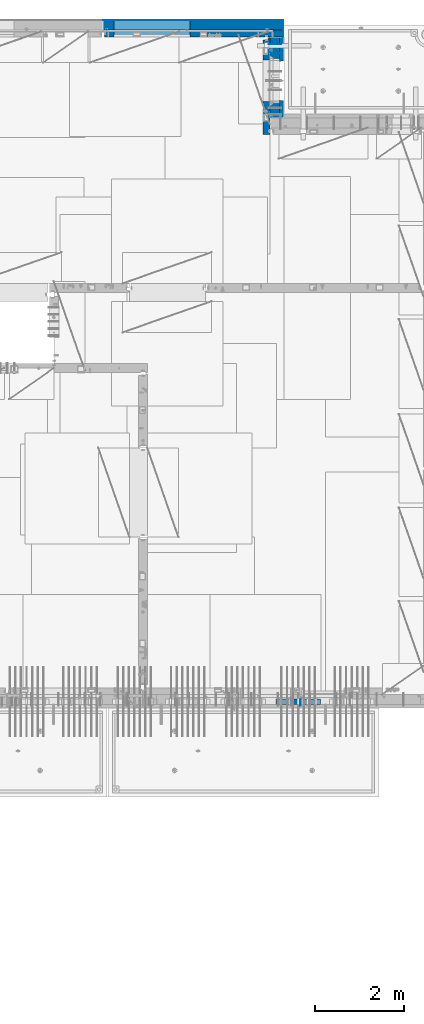
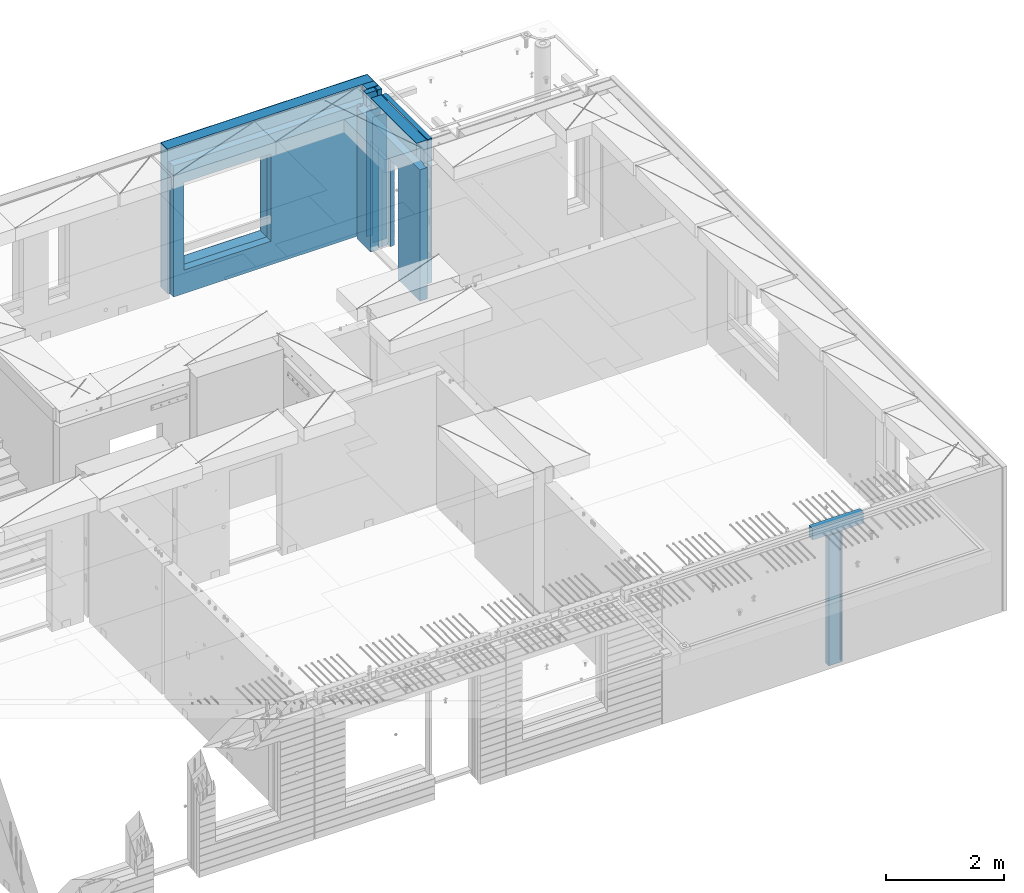
# One storey, part 232 of 341: 13 walls, 5 elements without a shape of their own.
"""IFC2X3 building model written with IfcOpenShell, lengths in millimetres."""

from ifc_helpers import new_model, si_unit, frame, origin_with_axes, place, context, subcontext, project, spatial, faceted_brep, material, type_object, element, aggregate, save


model = new_model("IFC2X3")

# Units and contexts
model_context = context("Model", 3, precision=1e-05, world=origin_with_axes())
body_context = subcontext(model_context, "Body", "Model", "MODEL_VIEW")
ifc_project = project(units=[si_unit("LENGTHUNIT", "METRE", prefix="MILLI"), si_unit("AREAUNIT", "SQUARE_METRE"), si_unit("VOLUMEUNIT", "CUBIC_METRE"), si_unit("MASSUNIT", "GRAM", prefix="KILO"), si_unit("TIMEUNIT", "SECOND"), si_unit("PLANEANGLEUNIT", "RADIAN"), si_unit("SOLIDANGLEUNIT", "STERADIAN"), si_unit("THERMODYNAMICTEMPERATUREUNIT", "DEGREE_CELSIUS"), si_unit("LUMINOUSINTENSITYUNIT", "LUMEN")], contexts=[model_context])

# Site, building, storey
site_placement = place(None, origin_with_axes())
site = spatial("IfcSite", under=ifc_project, at=site_placement, CompositionType="ELEMENT")
building_placement = place(site_placement, origin_with_axes())
building = spatial("IfcBuilding", under=site, at=building_placement, CompositionType="ELEMENT")
storey_placement = place(building_placement, origin_with_axes())
storey = spatial("IfcBuildingStorey", under=building, at=storey_placement, Name="5", CompositionType="ELEMENT", Elevation=0.0)

# Assembly, wall
assembly_1_placement = place(storey_placement, origin_with_axes())
assembly_1 = element("IfcElementAssembly", 1, at=assembly_1_placement, inside=storey, AssemblyPlace="NOTDEFINED", PredefinedType="REINFORCEMENT_UNIT")
ifc_material_1 = material(Name="Undefined")
wall_type_1 = type_object("IfcWallType", PredefinedType="NOTDEFINED")
wall_1_placement = place(assembly_1_placement, frame((32144.9998946285, 7780.0, 95115.0), z_axis=(0.0, 0.0, 1.0), x_axis=(0.0, -1.0, 0.0)))
wall_1 = element("IfcWall", 2, at=wall_1_placement, type_object=wall_type_1, material=ifc_material_1, Name="(PD)", context=body_context, shape_type="Brep", body=[
    faceted_brep([(0.0, 5.0, -1300.0), (0.0, 5.0, 1300.0), (180.0, 5.0, 1300.0), (180.0, 5.0, -1300.0), (0.0, -5.0, 1300.0), (180.0, -5.0, 1300.0), (0.0, -5.0, -1300.0), (180.0, -5.0, -1300.0)], [[[0, 1, 2, 3]], [[1, 4, 5, 2]], [[4, 6, 7, 5]], [[6, 0, 3, 7]], [[5, 7, 3, 2]], [[6, 4, 1, 0]]]),
])

# Assembly, walls
assembly_2_placement = place(storey_placement, origin_with_axes())
assembly_2 = element("IfcElementAssembly", 3, at=assembly_2_placement, inside=storey, AssemblyPlace="NOTDEFINED", PredefinedType="REINFORCEMENT_UNIT")
wall_2_placement = place(assembly_2_placement, frame((31429.9951872276, 22245.0, 95115.0), z_axis=(0.0, 0.0, 1.0), x_axis=(1.0, 0.0, 0.0)))
wall_2 = element("IfcWall", 4, at=wall_2_placement, type_object=wall_type_1, material=ifc_material_1, Name="(PD)", context=body_context, shape_type="Brep", body=[
    faceted_brep([(0.0, 5.0, -1300.0), (0.0, 5.0, 1300.0), (280.0, 5.0, 1300.0), (280.0, 5.0, -1300.0), (0.0, -5.0, 1300.0), (280.0, -5.0, 1300.0), (0.0, -5.0, -1300.0), (280.0, -5.0, -1300.0)], [[[0, 1, 2, 3]], [[1, 4, 5, 2]], [[4, 6, 7, 5]], [[6, 0, 3, 7]], [[5, 7, 3, 2]], [[6, 4, 1, 0]]]),
])
wall_3_placement = place(assembly_2_placement, frame((31429.9951872276, 22454.9997558594, 95115.0), z_axis=(0.0, 0.0, 1.0), x_axis=(1.0, 0.0, 0.0)))
wall_3 = element("IfcWall", 5, at=wall_3_placement, type_object=wall_type_1, material=ifc_material_1, Name="(PD)", context=body_context, shape_type="Brep", body=[
    faceted_brep([(0.0, 5.0, -1300.0), (0.0, 5.0, 1300.0), (280.0, 5.0, 1300.0), (280.0, 5.0, -1300.0), (0.0, -5.0, 1300.0), (280.0, -5.0, 1300.0), (0.0, -5.0, -1300.0), (280.0, -5.0, -1300.0)], [[[0, 1, 2, 3]], [[1, 4, 5, 2]], [[4, 6, 7, 5]], [[6, 0, 3, 7]], [[5, 7, 3, 2]], [[6, 4, 1, 0]]]),
])

# Assemblies, wall
assembly_3_placement = place(storey_placement, origin_with_axes())
assembly_3 = element("IfcElementAssembly", 6, at=assembly_3_placement, inside=storey, AssemblyPlace="NOTDEFINED", PredefinedType="REINFORCEMENT_UNIT")
assembly_4_placement = place(assembly_3_placement, origin_with_axes())
assembly_4 = element("IfcElementAssembly", 7, at=assembly_4_placement, Name="Steel Assembly", AssemblyPlace="NOTDEFINED", PredefinedType="NOTDEFINED")
aggregate(assembly_3, [assembly_4])
ifc_material_2 = material()
wall_type_2 = type_object("IfcWallType", PredefinedType="NOTDEFINED")
wall_4_placement = place(assembly_4_placement, frame((31599.9998568133, 7690.00021946163, 96590.0), z_axis=(0.0, 0.0, 1.0), x_axis=(1.0, 0.0, 0.0)))
wall_4 = element("IfcWall", 8, at=wall_4_placement, type_object=wall_type_2, material=ifc_material_2, context=body_context, shape_type="Brep", body=[
    faceted_brep([(0.0, 60.0, -120.0), (0.0, 60.0, 120.0), (1000.0, 60.0, 120.0), (1000.0, 60.0, -120.0), (0.0, -60.0, 120.0), (1000.0, -60.0, 120.0), (0.0, -60.0, -120.0), (1000.0, -60.0, -120.0)], [[[0, 1, 2, 3]], [[1, 4, 5, 2]], [[4, 6, 7, 5]], [[6, 0, 3, 7]], [[5, 7, 3, 2]], [[6, 4, 1, 0]]]),
])
aggregate(assembly_4, [wall_4])

# Assembly, walls
assembly_5_placement = place(storey_placement, origin_with_axes())
assembly_5 = element("IfcElementAssembly", 9, at=assembly_5_placement, inside=storey, AssemblyPlace="NOTDEFINED", PredefinedType="REINFORCEMENT_UNIT")
ifc_material_3 = material()
wall_type_3 = type_object("IfcWallType", PredefinedType="NOTDEFINED")
wall_5_placement = place(assembly_5_placement, frame((31645.0, 22620.0, 95247.5), z_axis=(0.0, 0.0, 1.0), x_axis=(0.0, 1.0, 0.0)))
wall_5 = element("IfcWall", 10, at=wall_5_placement, type_object=wall_type_3, material=ifc_material_3, context=body_context, shape_type="Brep", body=[
    faceted_brep([(0.0, 110.0, -1492.5), (0.0, 110.0, 1492.5), (150.0, 110.0, 1492.5), (150.0, 110.0, -1492.5), (0.0, -110.0, 1492.5), (150.0, -110.0, 1492.5), (0.0, -110.0, -1492.5), (150.0, -110.0, -1492.5)], [[[0, 1, 2, 3]], [[1, 4, 5, 2]], [[4, 6, 7, 5]], [[6, 0, 3, 7]], [[5, 7, 3, 2]], [[6, 4, 1, 0]]]),
])
wall_6_placement = place(assembly_5_placement, frame((27720.0, 22880.0, 95247.5), z_axis=(0.0, 0.0, 1.0), x_axis=(1.0, 0.0, 0.0)))
wall_6 = element("IfcWall", 11, at=wall_6_placement, type_object=wall_type_3, material=ifc_material_3, context=body_context, shape_type="Brep", body=[
    faceted_brep([(0.0, -110.0, -1492.5), (0.0, 110.0, -1492.5), (4035.0, 110.0, -1492.5), (4035.0, -110.0, -1492.5), (0.0, -110.0, 1492.5), (0.0, 110.0, 1492.5), (4035.0, -110.0, 1492.5), (4035.0, 110.0, 1492.5), (234.997879677034, 110.0, -1002.5), (1944.99787967703, 110.0, -1002.5), (1944.99787967703, 110.0, 807.5), (234.997879677034, 110.0, 807.5), (234.997879677034, -110.0, -1002.5), (234.997879677034, -110.0, 807.5), (1944.99787967703, -110.0, 807.5), (1944.99787967703, -110.0, -1002.5)], [[[0, 1, 2, 3]], [[0, 4, 5, 1]], [[5, 4, 6, 7]], [[1, 5, 7, 2], [8, 9, 10, 11]], [[6, 3, 2, 7]], [[4, 0, 3, 6], [12, 13, 14, 15]], [[10, 14, 13, 11]], [[9, 15, 14, 10]], [[8, 12, 15, 9]], [[11, 13, 12, 8]]]),
])

# Wall
ifc_material_4 = material(Name="COS5gt")
wall_7_placement = place(assembly_2_placement, frame((31569.9951872276, 22605.0, 95247.5), z_axis=(0.0, 0.0, 1.0), x_axis=(0.0, -1.0, 0.0)))
wall_7 = element("IfcWall", 12, at=wall_7_placement, type_object=wall_type_3, material=ifc_material_4, context=body_context, shape_type="Brep", body=[
    faceted_brep([(0.0, 90.0, -1492.5), (0.0, 90.0, -1442.5), (465.000109818619, 90.0, -1442.5), (465.000109818619, 90.0, -1492.5), (0.0, -110.0, -1492.5), (465.000109818619, -110.0, -1492.5), (1800.0, -110.0, 1492.5), (1800.0, 90.0, 1492.5), (255.0, 90.0, 1492.5), (255.0, -110.0, 1492.5), (1800.0, 90.0, -1442.5), (1800.0, 90.0, -1492.5), (1475.00010981862, 90.0, -1492.5), (1475.00010981862, 90.0, -1442.5), (1800.0, 110.0, -1442.5), (1475.00010981862, 110.0, -1442.5), (1800.0, 110.0, 1442.5), (1800.0, 90.0, 1442.5), (1800.0, -110.0, -1492.5), (1475.00010981862, -110.0, -1492.5), (1475.00010981862, -110.000000000004, 857.5), (1475.00010981862, 110.0, 857.5), (465.000109818619, -110.000000000004, 857.5), (465.000109818619, 110.0, 857.5), (255.0, -110.0, 1222.5), (105.0, -110.0, 1222.5), (105.0, -110.0, 1492.5), (0.0, -110.0, 1492.5), (0.0, 90.0, 1492.5), (105.0, 90.0, 1492.5), (0.0, 110.0, 1442.5), (0.0, 90.0, 1442.5), (105.0, 90.0, 1442.5), (105.0, 110.0, 1442.5), (0.0, 110.0, -1442.5), (465.000109818619, 110.0, -1442.5), (105.0, 110.0, 1222.5), (255.0, 110.0, 1222.5), (255.0, 110.0, 1442.5), (255.0, 90.0, 1442.5)], [[[0, 1, 2, 3]], [[4, 0, 3, 5]], [[6, 7, 8, 9]], [[10, 11, 12, 13]], [[14, 10, 13, 15]], [[16, 17, 7, 6, 18, 11, 10, 14]], [[11, 18, 19, 12]], [[15, 13, 12, 19, 20, 21]], [[21, 20, 22, 23]], [[19, 18, 6, 9, 24, 25, 26, 27, 4, 5, 22, 20]], [[28, 27, 26, 29]], [[30, 31, 32, 33]], [[0, 4, 27, 28, 31, 30, 34, 1]], [[1, 34, 35, 2]], [[23, 22, 5, 3, 2, 35]], [[34, 30, 33, 36, 37, 38, 16, 14, 15, 21, 23, 35]], [[17, 16, 38, 39]], [[7, 17, 39, 8]], [[38, 37, 24, 9, 8, 39]], [[36, 25, 24, 37]], [[33, 32, 29, 26, 25, 36]], [[31, 28, 29, 32]]]),
])

ifc_material_5 = material(Name="CONCRETE/C30/37")
wall_type_4 = type_object("IfcWallType", PredefinedType="NOTDEFINED")
wall_8_placement = place(assembly_2_placement, frame((31722.4951872276, 22605.0, 95247.5), z_axis=(0.0, 0.0, 1.0), x_axis=(0.0, -1.0, 0.0)))
wall_8 = element("IfcWall", 13, at=wall_8_placement, type_object=wall_type_4, material=ifc_material_5, context=body_context, shape_type="Brep", body=[
    faceted_brep([(0.0, 32.4999992507037, 744.999999999258), (0.0, 32.4999991127006, 755.00000040044), (526.17471776616, 32.4999991126897, 755.000000400425), (526.174717749924, 32.4999992507001, 744.999999999229), (0.0, 42.5, 742.999999944761), (524.998050995091, 42.4999995462422, 742.999999944761), (0.0, 42.5, 606.999999889245), (524.998050995091, 42.4999994639038, 606.999999889245), (3.63797880709171e-12, 32.4999991127006, 605.00000040044), (526.17471776616, 32.4999991126897, 605.000000400425), (3.63797880709171e-12, 32.4999992507037, 594.999999999258), (526.174717749924, 32.4999992507001, 594.999999999229), (0.0, 42.5, 592.999999944761), (524.998050995091, 42.4999995343132, 592.999999944761), (0.0, 42.5, 456.999999889245), (524.998050995091, 42.4999994639038, 456.999999889245), (0.0, 32.4999991127006, 455.00000040044), (526.17471776616, 32.4999991126897, 455.000000400425), (0.0, 32.4999992507037, 444.999999999258), (526.174717749924, 32.4999992507001, 444.999999999229), (0.0, 42.5, 442.999999944761), (524.998050995091, 42.4999995254038, 442.999999944761), (0.0, 42.5, 306.999999889245), (524.998050995091, 42.4999994639038, 306.999999889245), (-3.63797880709171e-12, 32.4999991127006, 305.00000040044), (526.17471776616, 32.4999991126897, 305.000000400425), (-3.63797880709171e-12, 32.4999992507037, 294.999999999258), (526.174717749924, 32.4999992507001, 294.999999999229), (0.0, 42.5, 292.999999944761), (524.998050995091, 42.499999518499, 292.999999944761), (0.0, 42.5, 156.999999889245), (524.998050995091, 42.4999994639038, 156.999999889245), (-3.63797880709171e-12, 32.4999991127006, 155.00000040044), (526.17471776616, 32.4999991126897, 155.000000400425), (-3.63797880709171e-12, 32.4999992507037, 144.999999999258), (526.174717749924, 32.4999992507001, 144.999999999229), (0.0, 42.5, 142.999999944761), (524.998050995091, 42.4999995129838, 142.999999944761), (0.0, 42.5, 6.99999988924537), (524.998050995091, 42.4999994639038, 6.99999988924537), (0.0, 32.4999991127006, 5.0000004004396), (526.17471776616, 32.4999991126897, 5.00000040042505), (0.0, 32.4999992507037, -5.00000000074215), (526.174717749924, 32.4999992507001, -5.00000000077125), (0.0, 42.5, -7.00000005523907), (524.998050995091, 42.49999950848, -7.00000005523907), (0.0, 42.5, -143.000000110755), (524.998050995091, 42.4999994639038, -143.000000110755), (3.63797880709171e-12, 32.4999991127006, -144.99999959956), (526.17471776616, 32.4999991126897, -144.999999599575), (3.63797880709171e-12, 32.4999992507037, -155.000000000742), (526.174717749924, 32.4999992507001, -155.000000000771), (0.0, 42.5, -157.000000055239), (524.998050995091, 42.4999995047365, -157.000000055239), (0.0, 42.5, -293.000000110755), (524.998050995091, 42.4999994639038, -293.000000110755), (0.0, 32.4999991127006, -294.99999959956), (526.17471776616, 32.4999991126897, -294.999999599575), (0.0, 32.4999992507037, -305.000000000742), (526.174717749924, 32.4999992507001, -305.000000000771), (0.0, 42.5, -307.000000055239), (524.998050995091, 42.4999995015714, -307.000000055239), (0.0, 42.5, -443.000000110755), (524.998050995091, 42.4999994639038, -443.000000110755), (0.0, 32.4999991127006, -444.99999959956), (526.17471776616, 32.4999991126897, -444.999999599575), (0.0, 32.4999992507037, -455.000000000742), (526.174717749924, 32.4999992507001, -455.000000000771), (0.0, 42.5, -457.000000055239), (524.998050995091, 42.4999994988648, -457.000000055239), (0.0, 42.5, -593.000000110755), (524.998050995091, 42.4999994639038, -593.000000110755), (3.63797880709171e-12, 32.4999991127006, -594.99999959956), (526.17471776616, 32.4999991126897, -594.999999599575), (3.63797880709171e-12, 32.4999992507037, -605.000000000742), (526.174717749924, 32.4999992507001, -605.000000000771), (0.0, 42.5, -607.000000055239), (524.998050995091, 42.4999994965183, -607.000000055239), (0.0, 42.5, -743.000000110755), (524.998050995091, 42.4999994639038, -743.000000110755), (0.0, 32.4999991127006, -744.99999959956), (526.17471776616, 32.4999991126897, -744.999999599575), (0.0, 32.4999992507037, -755.000000000742), (526.174717749924, 32.4999992507001, -755.000000000771), (0.0, 42.5, -757.000000055239), (524.998050995091, 42.4999994944665, -757.000000055239), (0.0, 42.5, -893.000000110755), (524.998050995091, 42.4999994639038, -893.000000110755), (0.0, 32.4999991127006, -894.99999959956), (526.17471776616, 32.4999991126897, -894.999999599575), (0.0, 32.4999992507037, -905.000000000742), (526.174717749924, 32.4999992507001, -905.000000000771), (0.0, 42.5, -907.000000055239), (524.998050995091, 42.4999994926584, -907.000000055239), (0.0, 42.5, -1043.00000011075), (524.998050995091, 42.4999994639038, -1043.00000011075), (0.0, 32.4999991127006, -1044.99999959956), (526.17471776616, 32.4999991126897, -1044.99999959957), (0.0, 32.4999992507037, -1055.00000000074), (526.174717749924, 32.4999992507001, -1055.00000000077), (0.0, 42.5, -1057.00000005524), (524.998050995091, 42.499999491054, -1057.00000005524), (0.0, 42.5, -1193.00000011075), (524.998050995091, 42.4999994639038, -1193.00000011075), (0.0, 32.4999991127006, -1194.99999959956), (526.17471776616, 32.4999991126897, -1194.99999959957), (0.0, 32.4999992507037, -1205.00000000074), (526.174717749924, 32.4999992507001, -1205.00000000077), (0.0, 42.5, -1207.00000005524), (524.998050995091, 42.499999489617, -1207.00000005524), (0.0, 42.5, -1343.00000011075), (524.998050995091, 42.4999994639038, -1343.00000011075), (0.0, 32.4999991127006, -1344.99999959956), (526.17471776616, 32.4999991126897, -1344.99999959957), (0.0, 32.4999992507037, -1355.00000000074), (526.174717749924, 32.4999992507001, -1355.00000000077), (0.0, 42.5, -1357.00000005524), (524.998050995091, 42.5, -1357.00000005524), (0.0, 42.5, -1492.5), (524.998050995091, 42.5, -1492.5), (0.0, 42.5, 1356.99999988925), (0.0, 42.5, 1492.5), (105.0, 42.5, 1492.5), (105.0, 42.499999287309, 1356.99999988925), (0.0, -42.5, 1492.5), (105.0, -42.5, 1492.5), (1800.0, 32.4999991126897, 755.000000400425), (1800.0, 32.4999992507001, 744.999999999229), (1413.82138424026, 32.4999992507001, 744.999999999229), (1413.82138422402, 32.4999991126897, 755.000000400425), (1800.0, 42.5, 742.999999944761), (1414.99805099509, 42.4999998629828, 742.999999944761), (1800.0, 42.5, 606.999999889245), (1414.99805099509, 42.4999998381209, 606.999999889245), (1800.0, 32.4999991126897, 605.000000400425), (1413.82138422402, 32.4999991126897, 605.000000400425), (1800.0, 32.4999992507001, 594.999999999229), (1413.82138424026, 32.4999992507001, 594.999999999229), (1800.0, 42.5, 592.999999944761), (1414.99805099509, 42.4999998593812, 592.999999944761), (1800.0, 42.5, 456.999999889245), (1414.99805099509, 42.4999998381209, 456.999999889245), (1800.0, 32.4999991126897, 455.000000400425), (1413.82138422402, 32.4999991126897, 455.000000400425), (1800.0, 32.4999992507001, 444.999999999229), (1413.82138424026, 32.4999992507001, 444.999999999229), (1800.0, 42.5, 442.999999944761), (1414.99805099509, 42.4999998566891, 442.999999944761), (1800.0, 42.5, 306.999999889245), (1414.99805099509, 42.4999998381209, 306.999999889245), (1800.0, 32.4999991126897, 305.000000400425), (1413.82138422402, 32.4999991126897, 305.000000400425), (1800.0, 32.4999992507001, 294.999999999229), (1413.82138424026, 32.4999992507001, 294.999999999229), (1800.0, 42.5, 292.999999944761), (1414.99805099509, 42.4999998546045, 292.999999944761), (1800.0, 42.5, 156.999999889245), (1414.99805099509, 42.4999998381209, 156.999999889245), (1800.0, 32.4999991126897, 155.000000400425), (1413.82138422402, 32.4999991126897, 155.000000400425), (1800.0, 32.4999992507001, 144.999999999229), (1413.82138424026, 32.4999992507001, 144.999999999229), (1800.0, 42.5, 142.999999944761), (1414.99805099509, 42.4999998529383, 142.999999944761), (1800.0, 42.5, 6.99999988924537), (1414.99805099509, 42.4999998381209, 6.99999988924537), (1800.0, 32.4999991126897, 5.00000040042505), (1413.82138422402, 32.4999991126897, 5.00000040042505), (1800.0, 32.4999992507001, -5.00000000077125), (1413.82138424026, 32.4999992507001, -5.00000000077125), (1800.0, 42.5, -7.00000005523907), (1414.99805099509, 42.4999998515814, -7.00000005523907), (1800.0, 42.5, -143.000000110755), (1414.99805099509, 42.4999998381209, -143.000000110755), (1800.0, 32.4999991126897, -144.999999599575), (1413.82138422402, 32.4999991126897, -144.999999599575), (1800.0, 32.4999992507001, -155.000000000771), (1413.82138424026, 32.4999992507001, -155.000000000771), (1800.0, 42.5, -157.000000055239), (1414.99805099509, 42.49999985045, -157.000000055239), (1800.0, 42.5, -293.000000110755), (1414.99805099509, 42.4999998381209, -293.000000110755), (1800.0, 32.4999991126897, -294.999999599575), (1413.82138422402, 32.4999991126897, -294.999999599575), (1800.0, 32.4999992507001, -305.000000000771), (1413.82138424026, 32.4999992507001, -305.000000000771), (1800.0, 42.5, -307.000000055239), (1414.99805099509, 42.4999998494932, -307.000000055239), (1800.0, 42.5, -443.000000110755), (1414.99805099509, 42.4999998381209, -443.000000110755), (1800.0, 32.4999991126897, -444.999999599575), (1413.82138422402, 32.4999991126897, -444.999999599575), (1800.0, 32.4999992507001, -455.000000000771), (1413.82138424026, 32.4999992507001, -455.000000000771), (1800.0, 42.5, -457.000000055239), (1414.99805099509, 42.4999998486746, -457.000000055239), (1800.0, 42.5, -593.000000110755), (1414.99805099509, 42.4999998381209, -593.000000110755), (1800.0, 32.4999991126897, -594.999999599575), (1413.82138422402, 32.4999991126897, -594.999999599575), (1800.0, 32.4999992507001, -605.000000000771), (1413.82138424026, 32.4999992507001, -605.000000000771), (1800.0, 42.5, -607.000000055239), (1414.99805099509, 42.4999998479689, -607.000000055239), (1800.0, 42.5, -743.000000110755), (1414.99805099509, 42.4999998381209, -743.000000110755), (1800.0, 32.4999991126897, -744.999999599575), (1413.82138422402, 32.4999991126897, -744.999999599575), (1800.0, 32.4999992507001, -755.000000000771), (1413.82138424026, 32.4999992507001, -755.000000000771), (1800.0, 42.5, -757.000000055239), (1414.99805099509, 42.4999998473468, -757.000000055239), (1800.0, 42.5, -893.000000110755), (1414.99805099509, 42.4999998381209, -893.000000110755), (1800.0, 32.4999991126897, -894.999999599575), (1413.82138422402, 32.4999991126897, -894.999999599575), (1800.0, 32.4999992507001, -905.000000000771), (1413.82138424026, 32.4999992507001, -905.000000000771), (1800.0, 42.5, -907.000000055239), (1414.99805099509, 42.4999998468011, -907.000000055239), (1800.0, 42.5, -1043.00000011075), (1414.99805099509, 42.4999998381209, -1043.00000011075), (1800.0, 32.4999991126897, -1044.99999959957), (1413.82138422402, 32.4999991126897, -1044.99999959957), (1800.0, 32.4999992507001, -1055.00000000077), (1413.82138424026, 32.4999992507001, -1055.00000000077), (1800.0, 42.5, -1057.00000005524), (1414.99805099509, 42.4999998463172, -1057.00000005524), (1800.0, 42.5, -1193.00000011075), (1414.99805099509, 42.4999998381209, -1193.00000011075), (1800.0, 32.4999991126897, -1194.99999959957), (1413.82138422402, 32.4999991126897, -1194.99999959957), (1800.0, 32.4999992507001, -1205.00000000077), (1413.82138424026, 32.4999992507001, -1205.00000000077), (1800.0, 42.5, -1207.00000005524), (1414.99805099509, 42.4999998458843, -1207.00000005524), (1800.0, 42.5, -1343.00000011075), (1414.99805099509, 42.4999998381209, -1343.00000011075), (1800.0, 32.4999991126897, -1344.99999959957), (1413.82138422402, 32.4999991126897, -1344.99999959957), (1800.0, 32.4999992507001, -1355.00000000077), (1413.82138424026, 32.4999992507001, -1355.00000000077), (1800.0, 42.5, -1357.00000005524), (1414.99805099509, 42.5, -1357.00000005524), (1800.0, 42.5, -1492.5), (1414.99805099509, 42.5, -1492.5), (1800.0, -42.5, -1492.5), (1404.99638432842, -42.5, -1492.5), (1414.99805099509, 42.4999998381209, 756.999999889245), (1404.99638432842, -42.5000000000036, 782.5), (1404.99638432842, -42.5000000000036, 787.502857142856), (1414.99805099509, 42.5, 782.5), (1800.0, 42.5, 756.999999889245), (0.0, 42.5, 892.999999944761), (0.0, 32.4999992507037, 894.999999999258), (1800.0, 32.4999992507001, 894.999999999229), (1800.0, 42.5, 892.999999944761), (0.0, 32.4999991127006, 905.00000040044), (1800.0, 32.4999991126897, 905.000000400425), (0.0, 42.5, 906.999999889245), (1800.0, 42.5, 906.999999889245), (0.0, 42.5, 1042.99999994476), (1800.0, 42.5, 1042.99999994476), (0.0, 32.4999992507037, 1044.99999999926), (1800.0, 32.4999992507001, 1044.99999999923), (0.0, 32.4999991127006, 1055.00000040044), (1800.0, 32.4999991126897, 1055.00000040043), (0.0, 42.5, 1056.99999988925), (1800.0, 42.5, 1056.99999988925), (0.0, 42.5, 1192.99999994476), (1800.0, 42.5, 1192.99999994476), (1800.0, -42.5, 1492.5), (1800.0, 42.5, 1492.5), (255.0, 42.5, 1492.5), (255.0, -42.5, 1492.5), (1800.0, 42.5, 1356.99999988925), (255.0, 42.499999350377, 1356.99999988925), (1800.0, 32.4999991126897, 1355.00000040043), (1800.0, 32.4999992507001, 1344.99999999923), (255.0, 32.4999992507001, 1344.99999999923), (255.0, 32.4999991126897, 1355.00000040043), (1800.0, 42.5, 1342.99999994476), (255.0, 42.4999996598308, 1342.99999994476), (105.0, 42.4999993874699, 1222.5), (105.0, -42.5, 1222.5), (255.0, -42.5, 1222.5), (255.0, 42.4999994355167, 1222.5), (1800.0, 32.4999992507001, 1194.99999999923), (1800.0, 32.4999991126897, 1205.00000040043), (1800.0, 42.5, 1206.99999988925), (0.0, 32.4999992507037, 1194.99999999926), (0.0, 32.4999991127006, 1205.00000040044), (0.0, 42.5, 1206.99999988925), (0.0, 42.5, 1342.99999994476), (105.0, 42.4999996268052, 1342.99999994476), (-3.63797880709171e-12, 32.4999992507037, 1344.99999999926), (105.0, 32.4999992507001, 1344.99999999923), (-3.63797880709171e-12, 32.4999991127006, 1355.00000040044), (105.0, 32.4999991126897, 1355.00000040043), (0.0, 42.5, 756.999999889245), (0.0, -42.5, -1492.5), (534.999717661754, -42.5, -1492.5), (534.999717661758, -42.5000000000036, 782.5), (534.999717661758, -42.5000000000036, 787.502857142856), (535.000109818619, 42.5, 782.5), (1405.00010981862, 42.5, 782.5), (524.998050995091, 42.5, 782.5), (524.998050995091, 42.4999994639038, 756.999999889245)], [[[0, 1, 2, 3]], [[4, 0, 3, 5]], [[6, 4, 5, 7]], [[8, 6, 7, 9]], [[10, 8, 9, 11]], [[12, 10, 11, 13]], [[14, 12, 13, 15]], [[16, 14, 15, 17]], [[18, 16, 17, 19]], [[20, 18, 19, 21]], [[22, 20, 21, 23]], [[24, 22, 23, 25]], [[26, 24, 25, 27]], [[28, 26, 27, 29]], [[30, 28, 29, 31]], [[32, 30, 31, 33]], [[34, 32, 33, 35]], [[36, 34, 35, 37]], [[38, 36, 37, 39]], [[40, 38, 39, 41]], [[42, 40, 41, 43]], [[44, 42, 43, 45]], [[46, 44, 45, 47]], [[48, 46, 47, 49]], [[50, 48, 49, 51]], [[52, 50, 51, 53]], [[54, 52, 53, 55]], [[56, 54, 55, 57]], [[58, 56, 57, 59]], [[60, 58, 59, 61]], [[62, 60, 61, 63]], [[64, 62, 63, 65]], [[66, 64, 65, 67]], [[68, 66, 67, 69]], [[70, 68, 69, 71]], [[72, 70, 71, 73]], [[74, 72, 73, 75]], [[76, 74, 75, 77]], [[78, 76, 77, 79]], [[80, 78, 79, 81]], [[82, 80, 81, 83]], [[84, 82, 83, 85]], [[86, 84, 85, 87]], [[88, 86, 87, 89]], [[90, 88, 89, 91]], [[92, 90, 91, 93]], [[94, 92, 93, 95]], [[96, 94, 95, 97]], [[98, 96, 97, 99]], [[100, 98, 99, 101]], [[102, 100, 101, 103]], [[104, 102, 103, 105]], [[106, 104, 105, 107]], [[108, 106, 107, 109]], [[110, 108, 109, 111]], [[112, 110, 111, 113]], [[114, 112, 113, 115]], [[116, 114, 115, 117]], [[118, 116, 117, 119]], [[120, 121, 122, 123]], [[121, 124, 125, 122]], [[126, 127, 128, 129]], [[127, 130, 131, 128]], [[130, 132, 133, 131]], [[132, 134, 135, 133]], [[134, 136, 137, 135]], [[136, 138, 139, 137]], [[138, 140, 141, 139]], [[140, 142, 143, 141]], [[142, 144, 145, 143]], [[144, 146, 147, 145]], [[146, 148, 149, 147]], [[148, 150, 151, 149]], [[150, 152, 153, 151]], [[152, 154, 155, 153]], [[154, 156, 157, 155]], [[156, 158, 159, 157]], [[158, 160, 161, 159]], [[160, 162, 163, 161]], [[162, 164, 165, 163]], [[164, 166, 167, 165]], [[166, 168, 169, 167]], [[168, 170, 171, 169]], [[170, 172, 173, 171]], [[172, 174, 175, 173]], [[174, 176, 177, 175]], [[176, 178, 179, 177]], [[178, 180, 181, 179]], [[180, 182, 183, 181]], [[182, 184, 185, 183]], [[184, 186, 187, 185]], [[186, 188, 189, 187]], [[188, 190, 191, 189]], [[190, 192, 193, 191]], [[192, 194, 195, 193]], [[194, 196, 197, 195]], [[196, 198, 199, 197]], [[198, 200, 201, 199]], [[200, 202, 203, 201]], [[202, 204, 205, 203]], [[204, 206, 207, 205]], [[206, 208, 209, 207]], [[208, 210, 211, 209]], [[210, 212, 213, 211]], [[212, 214, 215, 213]], [[214, 216, 217, 215]], [[216, 218, 219, 217]], [[218, 220, 221, 219]], [[220, 222, 223, 221]], [[222, 224, 225, 223]], [[224, 226, 227, 225]], [[226, 228, 229, 227]], [[228, 230, 231, 229]], [[230, 232, 233, 231]], [[232, 234, 235, 233]], [[234, 236, 237, 235]], [[236, 238, 239, 237]], [[238, 240, 241, 239]], [[240, 242, 243, 241]], [[242, 244, 245, 243]], [[244, 246, 247, 245]], [[248, 129, 128, 131, 133, 135, 137, 139, 141, 143, 145, 147, 149, 151, 153, 155, 157, 159, 161, 163, 165, 167, 169, 171, 173, 175, 177, 179, 181, 183, 185, 187, 189, 191, 193, 195, 197, 199, 201, 203, 205, 207, 209, 211, 213, 215, 217, 219, 221, 223, 225, 227, 229, 231, 233, 235, 237, 239, 241, 243, 245, 247, 249, 250, 251]], [[252, 126, 129, 248]], [[253, 254, 255, 256]], [[257, 258, 255, 254]], [[259, 260, 258, 257]], [[260, 259, 261, 262]], [[261, 263, 264, 262]], [[265, 266, 264, 263]], [[267, 268, 266, 265]], [[268, 267, 269, 270]], [[271, 272, 273, 274]], [[272, 275, 276, 273]], [[277, 278, 279, 280]], [[278, 281, 282, 279]], [[283, 284, 285, 286]], [[273, 276, 280, 279, 282, 286, 285, 274]], [[275, 277, 280, 276]], [[272, 271, 246, 244, 242, 240, 238, 236, 234, 232, 230, 228, 226, 224, 222, 220, 218, 216, 214, 212, 210, 208, 206, 204, 202, 200, 198, 196, 194, 192, 190, 188, 186, 184, 182, 180, 178, 176, 174, 172, 170, 168, 166, 164, 162, 160, 158, 156, 154, 152, 150, 148, 146, 144, 142, 140, 138, 136, 134, 132, 130, 127, 126, 252, 256, 255, 258, 260, 262, 264, 266, 268, 270, 287, 288, 289, 281, 278, 277, 275]], [[269, 290, 287, 270]], [[291, 288, 287, 290]], [[292, 289, 288, 291]], [[286, 282, 281, 289, 292, 293, 294, 283]], [[293, 295, 296, 294]], [[295, 297, 298, 296]], [[122, 125, 284, 283, 294, 296, 298, 123]], [[297, 120, 123, 298]], [[295, 293, 292, 291, 290, 269, 267, 265, 263, 261, 259, 257, 254, 253, 299, 1, 0, 4, 6, 8, 10, 12, 14, 16, 18, 20, 22, 24, 26, 28, 30, 32, 34, 36, 38, 40, 42, 44, 46, 48, 50, 52, 54, 56, 58, 60, 62, 64, 66, 68, 70, 72, 74, 76, 78, 80, 82, 84, 86, 88, 90, 92, 94, 96, 98, 100, 102, 104, 106, 108, 110, 112, 114, 116, 118, 300, 124, 121, 120, 297]], [[249, 247, 246, 271, 274, 285, 284, 125, 124, 300, 301, 302, 303, 250]], [[304, 305, 251, 250, 303, 306]], [[299, 253, 256, 252, 248, 251, 305, 304, 306, 307]], [[1, 299, 307, 2]], [[306, 303, 302, 301, 119, 117, 115, 113, 111, 109, 107, 105, 103, 101, 99, 97, 95, 93, 91, 89, 87, 85, 83, 81, 79, 77, 75, 73, 71, 69, 67, 65, 63, 61, 59, 57, 55, 53, 51, 49, 47, 45, 43, 41, 39, 37, 35, 33, 31, 29, 27, 25, 23, 21, 19, 17, 15, 13, 11, 9, 7, 5, 3, 2, 307]], [[300, 118, 119, 301]]]),
])

ifc_material_6 = material(Name="CONCRETE/C25/30")
wall_type_5 = type_object("IfcWallType", PredefinedType="NOTDEFINED")
wall_9_placement = place(assembly_5_placement, frame((27720.0, 22695.0, 95112.5), z_axis=(0.0, 0.0, 1.0), x_axis=(1.0, 0.0, 0.0)))
wall_9 = element("IfcWall", 14, at=wall_9_placement, type_object=wall_type_5, material=ifc_material_6, context=body_context, shape_type="Brep", body=[
    faceted_brep([(234.997879677034, 75.0, 942.5), (234.997879677034, -75.0, 942.5), (234.997879677034, -75.0, -867.5), (234.997879677034, 75.0, -867.5), (1944.99787967703, -75.0, -867.5), (1944.99787967703, 75.0, -867.5), (1944.99787967703, -75.0, 942.5), (1944.99787967703, 75.0, 942.5), (3815.0, -75.0, 1357.5), (3815.0, -75.0, -1357.5), (3815.0, 75.0, -1357.5), (3815.0, 75.0, 1357.5), (0.0, 75.0, -1357.5), (0.0, 75.0, 1357.5), (0.0, 45.0, -1357.5), (0.0, 45.0, 1357.5), (29.9999989126591, 32.0000004547946, -1357.5), (29.9999989126591, 32.0000004547946, 1357.5), (30.0000016637459, -75.0, -1357.5), (30.0000016637459, -75.0, 1357.5), (3624.99518722756, -75.0, 1357.5), (3637.99518722756, -55.0, 1357.5), (3691.99518722756, -55.0, 1357.5), (3704.99518722756, -75.0, 1357.5), (3704.99518722756, -75.0, -1357.5), (3637.99518722756, -55.0, -1357.5), (3624.99518722756, -75.0, -1357.5), (3691.99518722756, -55.0, -1357.5)], [[[0, 1, 2, 3]], [[3, 2, 4, 5]], [[5, 4, 6, 7]], [[7, 6, 1, 0]], [[8, 9, 10, 11]], [[12, 13, 11, 10], [3, 5, 7, 0]], [[13, 12, 14, 15]], [[15, 14, 16, 17]], [[17, 16, 18, 19]], [[8, 11, 13, 15, 17, 19, 20, 21, 22, 23]], [[9, 8, 23, 24]], [[25, 26, 18, 16, 14, 12, 10, 9, 24, 27]], [[23, 22, 27, 24]], [[21, 25, 27, 22]], [[20, 26, 25, 21]], [[19, 18, 26, 20], [2, 1, 6, 4]]]),
])

wall_10_placement = place(assembly_2_placement, frame((31384.9951872276, 22620.0, 95112.5), z_axis=(0.0, 0.0, 1.0), x_axis=(0.0, -1.0, 0.0)))
wall_10 = element("IfcWall", 15, at=wall_10_placement, type_object=wall_type_5, material=ifc_material_6, context=body_context, shape_type="Brep", body=[
    faceted_brep([(2190.00481277244, -75.0, 1357.5), (2190.00481277244, -75.0, -1357.5), (2190.00481277244, 75.0, -1357.5), (2190.00481277244, 75.0, 1357.5), (2168.00481277244, 75.0, -1357.5), (2168.00481277244, 75.0, 1357.5), (2155.00481277244, 55.0, -1357.5), (2155.00481277244, 55.0, 1357.5), (2075.00481277244, 55.0, -1357.5), (2075.00481277244, 55.0, 1357.5), (2062.00481277244, 75.0, 1357.5), (2062.00481277244, 75.0, -1357.5), (15.0, 75.0, 1357.5), (15.0, 53.6666666666642, 1357.5), (65.0, 32.0, 1357.5), (65.0, -75.0, 1357.5), (15.0, 75.0, -1357.5), (15.0, 53.6666666666642, -1357.5), (65.0, 32.0, -1357.5), (65.0, -75.0, -1357.5), (1450.00010981862, -75.0, -1357.5), (520.000109818619, -75.0, -1357.5), (520.000109818619, -75.0, 952.5), (1450.00010981862, -75.0, 952.5), (1446.15395597246, 75.0, -1357.5), (1446.15395597247, 75.0, 948.653846153844), (523.846263664771, 75.0, 948.653846153844), (523.846263664771, 75.0, -1357.5)], [[[0, 1, 2, 3]], [[3, 2, 4, 5]], [[5, 4, 6, 7]], [[7, 6, 8, 9]], [[10, 9, 8, 11]], [[12, 13, 14, 15, 0, 3, 5, 7, 9, 10]], [[12, 16, 17, 13]], [[13, 17, 18, 14]], [[14, 18, 19, 15]], [[20, 1, 0, 15, 19, 21, 22, 23]], [[11, 8, 6, 4, 2, 1, 20, 24]], [[16, 12, 10, 11, 24, 25, 26, 27]], [[19, 18, 17, 16, 27, 21]], [[26, 22, 21, 27]], [[25, 23, 22, 26]], [[24, 20, 23, 25]]]),
])

aggregate(assembly_2, [wall_2, wall_3, wall_8, wall_7, wall_10])

wall_type_6 = type_object("IfcWallType", PredefinedType="NOTDEFINED")
wall_11_placement = place(assembly_5_placement, frame((31760.0001313636, 22620.0, 95247.5), z_axis=(0.0, 0.0, 1.0), x_axis=(0.0, 1.0, 0.0)))
wall_11 = element("IfcWall", 16, at=wall_11_placement, type_object=wall_type_6, material=ifc_material_5, context=body_context, shape_type="Brep", body=[
    faceted_brep([(0.0, 5.0, -1492.5), (0.0, 5.0, 1492.5), (370.0, 5.0, 1492.5), (370.0, 5.0, -1492.5), (0.0, -5.0, 1492.5), (370.0, -5.0, 1492.5), (0.0, -5.0, -1492.5), (370.0, -5.0, -1492.5)], [[[0, 1, 2, 3]], [[1, 4, 5, 2]], [[4, 6, 7, 5]], [[6, 0, 3, 7]], [[5, 7, 3, 2]], [[6, 4, 1, 0]]]),
])

wall_12_placement = place(assembly_5_placement, frame((27720.0, 22995.0, 95247.5), z_axis=(0.0, 0.0, 1.0), x_axis=(1.0, 0.0, 0.0)))
wall_12 = element("IfcWall", 17, at=wall_12_placement, type_object=wall_type_6, material=ifc_material_5, context=body_context, shape_type="Brep", body=[
    faceted_brep([(0.0, -5.0, -1492.5), (0.0, 5.0, -1492.5), (4045.0, 5.0, -1492.5), (4045.0, -5.0, -1492.5), (0.0, -5.0, 1492.5), (0.0, 5.0, 1492.5), (4045.0, -5.0, 1492.5), (4045.0, 5.0, 1492.5), (234.997879677034, 5.0, -1002.5), (1944.99787967703, 5.0, -1002.5), (1944.99787967703, 5.0, 807.5), (234.997879677034, 5.0, 807.5), (234.997879677034, -5.0, -1002.5), (234.997879677034, -5.0, 807.5), (1944.99787967703, -5.0, 807.5), (1944.99787967703, -5.0, -1002.5)], [[[0, 1, 2, 3]], [[0, 4, 5, 1]], [[5, 4, 6, 7]], [[1, 5, 7, 2], [8, 9, 10, 11]], [[6, 3, 2, 7]], [[4, 0, 3, 6], [12, 13, 14, 15]], [[10, 14, 13, 11]], [[9, 15, 14, 10]], [[8, 12, 15, 9]], [[11, 13, 12, 8]]]),
])

aggregate(assembly_5, [wall_11, wall_5, wall_12, wall_6, wall_9])

ifc_material_7 = material(Name="SPU")
wall_type_7 = type_object("IfcWallType", PredefinedType="NOTDEFINED")
wall_13_placement = place(assembly_1_placement, frame((32195.0000381475, 7690.0, 95102.5), z_axis=(0.0, 0.0, 1.0), x_axis=(-1.0, 3.00000001838171e-08, 0.0)))
wall_13 = element("IfcWall", 18, at=wall_13_placement, type_object=wall_type_7, material=ifc_material_7, context=body_context, shape_type="Brep", body=[
    faceted_brep([(0.0, 60.0, -1347.5), (0.0, 60.0, 1347.5), (270.001908754726, 60.0, 1347.5), (270.001908754726, 60.0, -1347.5), (0.0, -60.0, 1347.5), (270.001908754726, -60.0, 1347.5), (0.0, -60.0, -1347.5), (270.001908754726, -60.0, -1347.5)], [[[0, 1, 2, 3]], [[1, 4, 5, 2]], [[4, 6, 7, 5]], [[6, 0, 3, 7]], [[5, 7, 3, 2]], [[6, 4, 1, 0]]]),
])

aggregate(assembly_1, [wall_1, wall_13])

save(model, "model.ifc")
